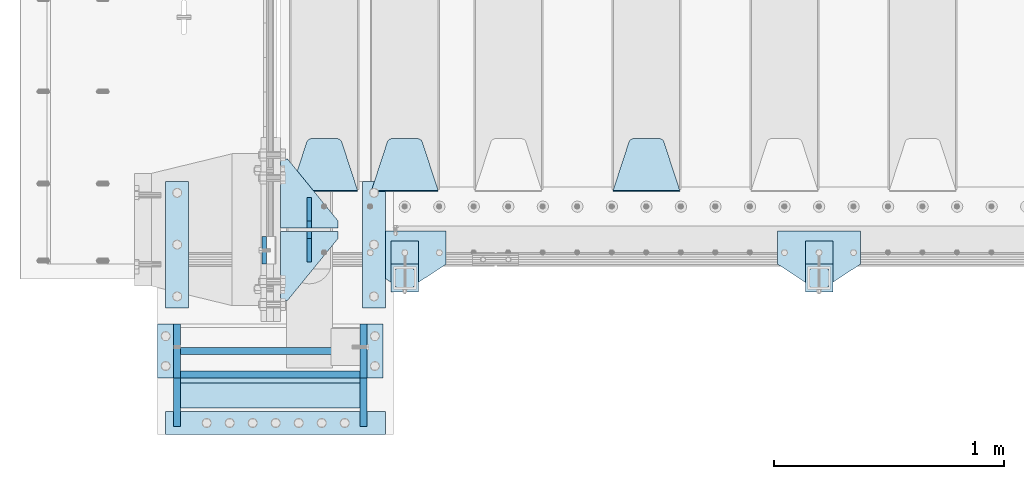
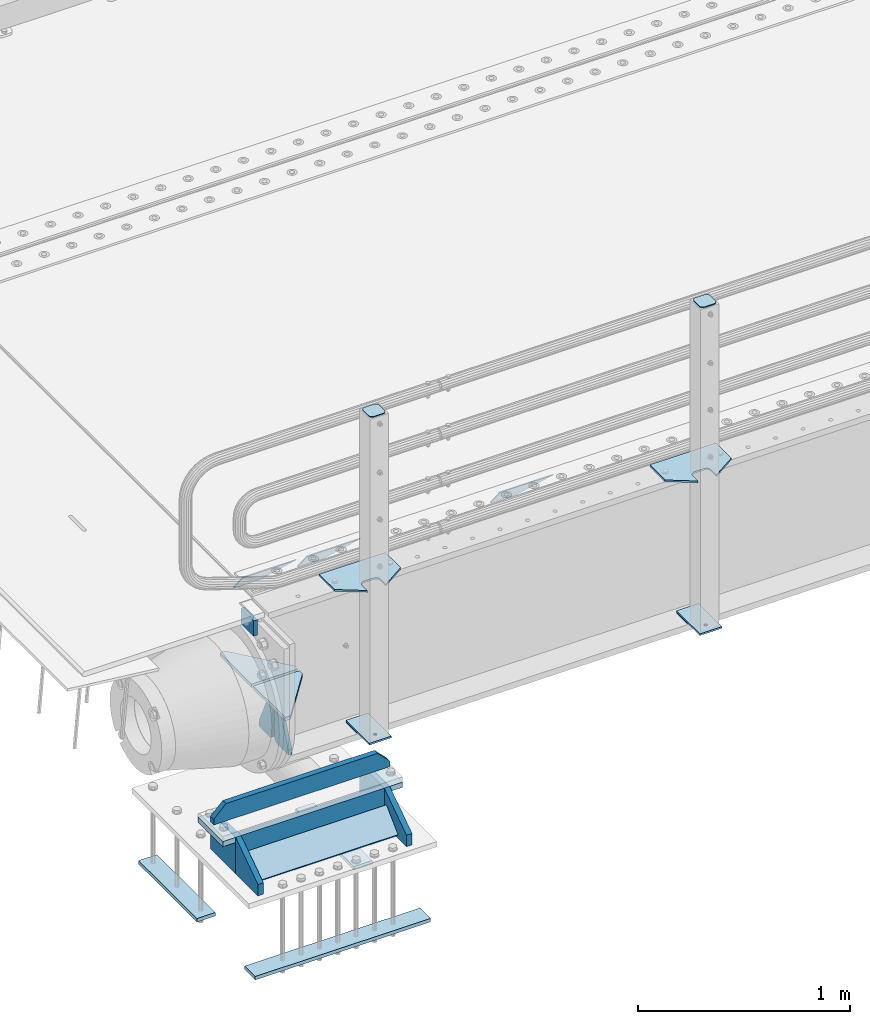
# One storey, part 195 of 242: 28 plates.
"""IFC2X3 building model written with IfcOpenShell, lengths in millimetres."""

from ifc_helpers import new_model, si_unit, frame, origin_with_axes, place, context, subcontext, project, spatial, faceted_brep, material, type_object, element, save


model = new_model("IFC2X3")

# Units and contexts
model_context = context("Model", 3, precision=1e-05, world=origin_with_axes())
body_context = subcontext(model_context, "Body", "Model", "MODEL_VIEW")
ifc_project = project(units=[si_unit("LENGTHUNIT", "METRE", prefix="MILLI"), si_unit("AREAUNIT", "SQUARE_METRE"), si_unit("VOLUMEUNIT", "CUBIC_METRE"), si_unit("MASSUNIT", "GRAM", prefix="KILO"), si_unit("TIMEUNIT", "SECOND"), si_unit("PLANEANGLEUNIT", "RADIAN"), si_unit("SOLIDANGLEUNIT", "STERADIAN"), si_unit("THERMODYNAMICTEMPERATUREUNIT", "DEGREE_CELSIUS"), si_unit("LUMINOUSINTENSITYUNIT", "LUMEN")], contexts=[model_context])

# Site, building, storey
site_placement = place(None, origin_with_axes())
site = spatial("IfcSite", under=ifc_project, at=site_placement, CompositionType="ELEMENT")
building_placement = place(site_placement, origin_with_axes())
building = spatial("IfcBuilding", under=site, at=building_placement, Name="Standard", CompositionType="ELEMENT")
storey_placement = place(building_placement, origin_with_axes())
storey = spatial("IfcBuildingStorey", under=building, at=storey_placement, Name="Undefined", CompositionType="ELEMENT", Elevation=0.0)

# Plates
ifc_material_1 = material(Name="STEEL/S355N")
plate_type_1 = type_object("IfcPlateType", PredefinedType="NOTDEFINED")
plate_1_placement = place(storey_placement, frame((-42510.0, -24029.9995540189, -106.00008741594), z_axis=(1.0000003385235e-09, -0.999999999987744, -4.95099999993936e-06), x_axis=(0.0, -4.95099997756316e-06, 0.999999999987744)))
element("IfcPlate", 1, at=plate_1_placement, inside=storey, type_object=plate_type_1, material=ifc_material_1, context=body_context, shape_type="Brep", body=[
    faceted_brep([(0.0, -10.0, 0.0), (5.70725632087488e-07, -10.0, 120.0), (5.70725632087488e-07, 10.0, 120.0), (0.0, 10.0, 0.0), (89.9999999999979, -10.0, 120.000000000004), (89.9999999999979, 10.0, 120.000000000004), (90.0, -10.0, 1.09139364212751e-11), (90.0, 10.0, 1.09139364212751e-11)], [[[0, 1, 2, 3]], [[1, 4, 5, 2]], [[4, 6, 7, 5]], [[6, 0, 3, 7]], [[5, 7, 3, 2]], [[6, 4, 1, 0]]]),
])
ifc_material_2 = material(Name="STEEL/S355J2")
plate_type_2 = type_object("IfcPlateType", PredefinedType="NOTDEFINED")
plate_2_placement = place(storey_placement, frame((-39920.0, -24005.0, 5.00000000004911), z_axis=(0.0, -1.0, 0.0), x_axis=(-1.0, 0.0, 0.0)))
element("IfcPlate", 2, at=plate_2_placement, inside=storey, type_object=plate_type_2, material=ifc_material_2, context=body_context, shape_type="Brep", body=[
    faceted_brep([(0.0, -5.0, 0.0), (2.31396552408114e-06, -5.0, 145.0), (2.31396552408114e-06, 5.0, 145.0), (0.0, 5.0, 0.0), (130.0, -5.0, 230.0), (130.0, 5.0, 230.0), (130.0, -5.0, 180.0), (130.0, 5.0, 180.0), (130.48036798992, -5.0, 175.122741949595), (130.48036798992, 5.0, 175.122741949595), (131.903011687216, -5.0, 170.432914190871), (131.903011687216, 5.0, 170.432914190871), (134.213259692435, -5.0, 166.110744174512), (134.213259692435, 5.0, 166.110744174512), (137.322330470335, -5.0, 162.322330470335), (137.322330470335, 5.0, 162.322330470335), (141.110744174512, -5.0, 159.213259692435), (141.110744174512, 5.0, 159.213259692435), (145.432914190871, -5.0, 156.903011687216), (145.432914190871, 5.0, 156.903011687216), (150.122741949595, -5.0, 155.48036798992), (150.122741949595, 5.0, 155.48036798992), (155.0, -5.0, 155.0), (155.0, 5.0, 155.0), (205.0, -5.0, 155.0), (205.0, 5.0, 155.0), (209.877258050405, -5.0, 155.48036798992), (209.877258050405, 5.0, 155.48036798992), (214.567085809129, -5.0, 156.903011687216), (214.567085809129, 5.0, 156.903011687216), (218.889255825488, -5.0, 159.213259692435), (218.889255825488, 5.0, 159.213259692435), (222.677669529665, -5.0, 162.322330470335), (222.677669529665, 5.0, 162.322330470335), (225.786740307565, -5.0, 166.110744174512), (225.786740307565, 5.0, 166.110744174512), (228.096988312784, -5.0, 170.432914190871), (228.096988312784, 5.0, 170.432914190871), (229.51963201008, -5.0, 175.122741949595), (229.51963201008, 5.0, 175.122741949595), (230.0, -5.0, 180.0), (230.0, 5.0, 180.0), (230.0, -5.0, 230.0), (230.0, 5.0, 230.0), (360.0, -5.0, 145.0), (360.0, 5.0, 145.0), (360.0, -5.0, -7.27595761418343e-12), (360.0, 5.0, -7.27595761418343e-12)], [[[0, 1, 2, 3]], [[1, 4, 5, 2]], [[4, 6, 7, 5]], [[6, 8, 9, 7]], [[8, 10, 11, 9]], [[10, 12, 13, 11]], [[12, 14, 15, 13]], [[14, 16, 17, 15]], [[16, 18, 19, 17]], [[18, 20, 21, 19]], [[20, 22, 23, 21]], [[22, 24, 25, 23]], [[24, 26, 27, 25]], [[26, 28, 29, 27]], [[28, 30, 31, 29]], [[30, 32, 33, 31]], [[32, 34, 35, 33]], [[34, 36, 37, 35]], [[36, 38, 39, 37]], [[38, 40, 41, 39]], [[40, 42, 43, 41]], [[42, 44, 45, 43]], [[44, 46, 47, 45]], [[46, 0, 3, 47]], [[5, 7, 9, 11, 13, 15, 17, 19, 21, 23, 25, 27, 29, 31, 33, 35, 37, 39, 41, 43, 45, 47, 3, 2]], [[46, 44, 42, 40, 38, 36, 34, 32, 30, 28, 26, 24, 22, 20, 18, 16, 14, 12, 10, 8, 6, 4, 1, 0]]]),
])
plate_3_placement = place(storey_placement, frame((-41720.0, -24005.0, 5.00000000004911), z_axis=(0.0, -1.0, 0.0), x_axis=(-1.0, 0.0, 0.0)))
element("IfcPlate", 3, at=plate_3_placement, inside=storey, type_object=plate_type_2, material=ifc_material_2, context=body_context, shape_type="Brep", body=[
    faceted_brep([(0.0, -5.0, 0.0), (2.31396552408114e-06, -5.0, 145.0), (2.31396552408114e-06, 5.0, 145.0), (0.0, 5.0, 0.0), (130.0, -5.0, 230.0), (130.0, 5.0, 230.0), (130.0, -5.0, 180.0), (130.0, 5.0, 180.0), (130.48036798992, -5.0, 175.122741949595), (130.48036798992, 5.0, 175.122741949595), (131.903011687216, -5.0, 170.432914190871), (131.903011687216, 5.0, 170.432914190871), (134.213259692435, -5.0, 166.110744174512), (134.213259692435, 5.0, 166.110744174512), (137.322330470335, -5.0, 162.322330470335), (137.322330470335, 5.0, 162.322330470335), (141.110744174512, -5.0, 159.213259692435), (141.110744174512, 5.0, 159.213259692435), (145.432914190871, -5.0, 156.903011687216), (145.432914190871, 5.0, 156.903011687216), (150.122741949595, -5.0, 155.48036798992), (150.122741949595, 5.0, 155.48036798992), (155.0, -5.0, 155.0), (155.0, 5.0, 155.0), (205.0, -5.0, 155.0), (205.0, 5.0, 155.0), (209.877258050405, -5.0, 155.48036798992), (209.877258050405, 5.0, 155.48036798992), (214.567085809129, -5.0, 156.903011687216), (214.567085809129, 5.0, 156.903011687216), (218.889255825488, -5.0, 159.213259692435), (218.889255825488, 5.0, 159.213259692435), (222.677669529665, -5.0, 162.322330470335), (222.677669529665, 5.0, 162.322330470335), (225.786740307565, -5.0, 166.110744174512), (225.786740307565, 5.0, 166.110744174512), (228.096988312784, -5.0, 170.432914190871), (228.096988312784, 5.0, 170.432914190871), (229.51963201008, -5.0, 175.122741949595), (229.51963201008, 5.0, 175.122741949595), (230.0, -5.0, 180.0), (230.0, 5.0, 180.0), (230.0, -5.0, 230.0), (230.0, 5.0, 230.0), (360.0, -5.0, 145.0), (360.0, 5.0, 145.0), (360.0, -5.0, -7.27595761418343e-12), (360.0, 5.0, -7.27595761418343e-12)], [[[0, 1, 2, 3]], [[1, 4, 5, 2]], [[4, 6, 7, 5]], [[6, 8, 9, 7]], [[8, 10, 11, 9]], [[10, 12, 13, 11]], [[12, 14, 15, 13]], [[14, 16, 17, 15]], [[16, 18, 19, 17]], [[18, 20, 21, 19]], [[20, 22, 23, 21]], [[22, 24, 25, 23]], [[24, 26, 27, 25]], [[26, 28, 29, 27]], [[28, 30, 31, 29]], [[30, 32, 33, 31]], [[32, 34, 35, 33]], [[34, 36, 37, 35]], [[36, 38, 39, 37]], [[38, 40, 41, 39]], [[40, 42, 43, 41]], [[42, 44, 45, 43]], [[44, 46, 47, 45]], [[46, 0, 3, 47]], [[5, 7, 9, 11, 13, 15, 17, 19, 21, 23, 25, 27, 29, 31, 33, 35, 37, 39, 41, 43, 45, 47, 3, 2]], [[46, 44, 42, 40, 38, 36, 34, 32, 30, 28, 26, 24, 22, 20, 18, 16, 14, 12, 10, 8, 6, 4, 1, 0]]]),
])
plate_type_3 = type_object("IfcPlateType", PredefinedType="NOTDEFINED")
for number, where, z_axis, x_axis in (
    (4, (-40040.0000000001, -24050.0000000002, -850.000000000002), (0.0, -1.0, 0.0), (-1.0, 0.0, 0.0)),
    (5, (-41840.0000000001, -24050.0000000002, -850.000000000002), (0.0, -1.0, 0.0), (-1.0, 0.0, 0.0)),
):
    element("IfcPlate", number, at=place(storey_placement, frame(where, z_axis=z_axis, x_axis=x_axis)), inside=storey, type_object=plate_type_3, material=ifc_material_2, context=body_context, shape_type="Brep", body=[
        faceted_brep([(53.6360389691836, -5.0, 176.363961030471), (53.6360389691836, 5.0, 176.363961030471), (59.9999999998618, 5.0, 178.999999999793), (59.9999999998618, -5.0, 178.999999999793), (66.3639610305399, 5.0, 176.363961030471), (66.3639610305399, -5.0, 176.363961030471), (68.9999999998618, 5.0, 169.999999999793), (68.9999999998618, -5.0, 169.999999999793), (66.3639610305399, 5.0, 163.636038969114), (66.3639610305399, -5.0, 163.636038969114), (59.9999999998618, 5.0, 160.999999999793), (59.9999999998618, -5.0, 160.999999999793), (53.6360389691836, 5.0, 163.636038969114), (53.6360389691836, -5.0, 163.636038969114), (50.9999999998618, 5.0, 169.999999999793), (50.9999999998618, -5.0, 169.999999999793), (120.0, -5.0, 0.0), (120.0, -5.0, 220.0), (0.0, -5.0, 220.0), (0.0, -5.0, 0.0), (0.0, 5.0, 0.0), (120.0, 5.0, 0.0), (120.0, 5.0, 220.0), (0.0, 5.0, 220.0)], [[[0, 1, 2, 3]], [[3, 2, 4, 5]], [[5, 4, 6, 7]], [[7, 6, 8, 9]], [[9, 8, 10, 11]], [[11, 10, 12, 13]], [[13, 12, 14, 15]], [[15, 14, 1, 0]], [[16, 17, 18, 19], [3, 5, 7, 9, 11, 13, 15, 0]], [[16, 19, 20, 21]], [[17, 16, 21, 22]], [[18, 17, 22, 23]], [[19, 18, 23, 20]], [[22, 21, 20, 23], [10, 8, 6, 4, 2, 1, 14, 12]]]),
    ])
plate_type_4 = type_object("IfcPlateType", PredefinedType="NOTDEFINED")
plate_4_placement = place(storey_placement, frame((-40144.0000000001, -24166.0000000002, 1012.50000000001), z_axis=(0.0, -1.0, 0.0), x_axis=(1.0, 0.0, 0.0)))
element("IfcPlate", 6, at=plate_4_placement, inside=storey, type_object=plate_type_4, material=ifc_material_2, context=body_context, shape_type="Brep", body=[
    faceted_brep([(0.0, -2.5, 19.0), (0.0, -2.5, 69.0), (0.0, 2.5, 69.0), (0.0, 2.5, 19.0), (0.476369668544066, -2.5, 73.2278977451715), (0.476369668544066, 2.5, 73.2278977451715), (1.88159150985302, -2.5, 77.2437910432345), (1.88159150985302, 2.5, 77.2437910432345), (4.14520183310742, -2.5, 80.8463062353148), (4.14520183310742, 2.5, 80.8463062353148), (7.15369376468516, -2.5, 83.8547981668926), (7.15369376468516, 2.5, 83.8547981668926), (10.7562089567655, -2.5, 86.118408490147), (10.7562089567655, 2.5, 86.118408490147), (14.7721022548285, -2.5, 87.5236303314559), (14.7721022548285, 2.5, 87.5236303314559), (19.0, -2.5, 88.0), (19.0, 2.5, 88.0), (69.0, -2.5, 88.0), (69.0, 2.5, 88.0), (73.2278977451715, -2.5, 87.5236303314559), (73.2278977451715, 2.5, 87.5236303314559), (77.2437910432345, -2.5, 86.118408490147), (77.2437910432345, 2.5, 86.118408490147), (80.8463062353148, -2.5, 83.8547981668926), (80.8463062353148, 2.5, 83.8547981668926), (83.8547981668926, -2.5, 80.8463062353148), (83.8547981668926, 2.5, 80.8463062353148), (86.118408490147, -2.5, 77.2437910432345), (86.118408490147, 2.5, 77.2437910432345), (87.5236303314559, -2.5, 73.2278977451715), (87.5236303314559, 2.5, 73.2278977451715), (88.0, -2.5, 69.0), (88.0, 2.5, 69.0), (88.0, -2.5, 19.0), (88.0, 2.5, 19.0), (87.5236303314559, -2.5, 14.7721022548285), (87.5236303314559, 2.5, 14.7721022548285), (86.118408490147, -2.5, 10.7562089567655), (86.118408490147, 2.5, 10.7562089567655), (83.8547981668926, -2.5, 7.15369376468516), (83.8547981668926, 2.5, 7.15369376468516), (80.8463062353148, -2.5, 4.14520183310742), (80.8463062353148, 2.5, 4.14520183310742), (77.2437910432345, -2.5, 1.88159150985302), (77.2437910432345, 2.5, 1.88159150985302), (73.2278977451715, -2.5, 0.476369668544066), (73.2278977451715, 2.5, 0.476369668544066), (69.0, -2.5, 0.0), (69.0, 2.5, 0.0), (19.0, -2.5, 0.0), (19.0, 2.5, 0.0), (14.7721022548285, -2.5, 0.476369668544066), (14.7721022548285, 2.5, 0.476369668544066), (10.7562089567655, -2.5, 1.88159150985302), (10.7562089567655, 2.5, 1.88159150985302), (7.15369376468516, -2.5, 4.14520183310742), (7.15369376468516, 2.5, 4.14520183310742), (4.14520183310742, -2.5, 7.15369376468516), (4.14520183310742, 2.5, 7.15369376468516), (1.88159150985302, -2.5, 10.7562089567655), (1.88159150985302, 2.5, 10.7562089567655), (0.476369668544066, -2.5, 14.7721022548285), (0.476369668544066, 2.5, 14.7721022548285)], [[[0, 1, 2, 3]], [[1, 4, 5, 2]], [[4, 6, 7, 5]], [[6, 8, 9, 7]], [[8, 10, 11, 9]], [[10, 12, 13, 11]], [[12, 14, 15, 13]], [[14, 16, 17, 15]], [[16, 18, 19, 17]], [[18, 20, 21, 19]], [[20, 22, 23, 21]], [[22, 24, 25, 23]], [[24, 26, 27, 25]], [[26, 28, 29, 27]], [[28, 30, 31, 29]], [[30, 32, 33, 31]], [[32, 34, 35, 33]], [[34, 36, 37, 35]], [[36, 38, 39, 37]], [[38, 40, 41, 39]], [[40, 42, 43, 41]], [[42, 44, 45, 43]], [[44, 46, 47, 45]], [[46, 48, 49, 47]], [[48, 50, 51, 49]], [[50, 52, 53, 51]], [[52, 54, 55, 53]], [[54, 56, 57, 55]], [[56, 58, 59, 57]], [[58, 60, 61, 59]], [[60, 62, 63, 61]], [[62, 0, 3, 63]], [[5, 7, 9, 11, 13, 15, 17, 19, 21, 23, 25, 27, 29, 31, 33, 35, 37, 39, 41, 43, 45, 47, 49, 51, 53, 55, 57, 59, 61, 63, 3, 2]], [[62, 60, 58, 56, 54, 52, 50, 48, 46, 44, 42, 40, 38, 36, 34, 32, 30, 28, 26, 24, 22, 20, 18, 16, 14, 12, 10, 8, 6, 4, 1, 0]]]),
])
plate_5_placement = place(storey_placement, frame((-41944.0000000001, -24166.0000000002, 1012.50000000001), z_axis=(0.0, -1.0, 0.0), x_axis=(1.0, 0.0, 0.0)))
element("IfcPlate", 7, at=plate_5_placement, inside=storey, type_object=plate_type_4, material=ifc_material_2, context=body_context, shape_type="Brep", body=[
    faceted_brep([(0.0, -2.5, 19.0), (0.0, -2.5, 69.0), (0.0, 2.5, 69.0), (0.0, 2.5, 19.0), (0.476369668544066, -2.5, 73.2278977451715), (0.476369668544066, 2.5, 73.2278977451715), (1.88159150985302, -2.5, 77.2437910432345), (1.88159150985302, 2.5, 77.2437910432345), (4.14520183310742, -2.5, 80.8463062353148), (4.14520183310742, 2.5, 80.8463062353148), (7.15369376468516, -2.5, 83.8547981668926), (7.15369376468516, 2.5, 83.8547981668926), (10.7562089567655, -2.5, 86.118408490147), (10.7562089567655, 2.5, 86.118408490147), (14.7721022548285, -2.5, 87.5236303314559), (14.7721022548285, 2.5, 87.5236303314559), (19.0, -2.5, 88.0), (19.0, 2.5, 88.0), (69.0, -2.5, 88.0), (69.0, 2.5, 88.0), (73.2278977451715, -2.5, 87.5236303314559), (73.2278977451715, 2.5, 87.5236303314559), (77.2437910432345, -2.5, 86.118408490147), (77.2437910432345, 2.5, 86.118408490147), (80.8463062353148, -2.5, 83.8547981668926), (80.8463062353148, 2.5, 83.8547981668926), (83.8547981668926, -2.5, 80.8463062353148), (83.8547981668926, 2.5, 80.8463062353148), (86.118408490147, -2.5, 77.2437910432345), (86.118408490147, 2.5, 77.2437910432345), (87.5236303314559, -2.5, 73.2278977451715), (87.5236303314559, 2.5, 73.2278977451715), (88.0, -2.5, 69.0), (88.0, 2.5, 69.0), (88.0, -2.5, 19.0), (88.0, 2.5, 19.0), (87.5236303314559, -2.5, 14.7721022548285), (87.5236303314559, 2.5, 14.7721022548285), (86.118408490147, -2.5, 10.7562089567655), (86.118408490147, 2.5, 10.7562089567655), (83.8547981668926, -2.5, 7.15369376468516), (83.8547981668926, 2.5, 7.15369376468516), (80.8463062353148, -2.5, 4.14520183310742), (80.8463062353148, 2.5, 4.14520183310742), (77.2437910432345, -2.5, 1.88159150985302), (77.2437910432345, 2.5, 1.88159150985302), (73.2278977451715, -2.5, 0.476369668544066), (73.2278977451715, 2.5, 0.476369668544066), (69.0, -2.5, 0.0), (69.0, 2.5, 0.0), (19.0, -2.5, 0.0), (19.0, 2.5, 0.0), (14.7721022548285, -2.5, 0.476369668544066), (14.7721022548285, 2.5, 0.476369668544066), (10.7562089567655, -2.5, 1.88159150985302), (10.7562089567655, 2.5, 1.88159150985302), (7.15369376468516, -2.5, 4.14520183310742), (7.15369376468516, 2.5, 4.14520183310742), (4.14520183310742, -2.5, 7.15369376468516), (4.14520183310742, 2.5, 7.15369376468516), (1.88159150985302, -2.5, 10.7562089567655), (1.88159150985302, 2.5, 10.7562089567655), (0.476369668544066, -2.5, 14.7721022548285), (0.476369668544066, 2.5, 14.7721022548285)], [[[0, 1, 2, 3]], [[1, 4, 5, 2]], [[4, 6, 7, 5]], [[6, 8, 9, 7]], [[8, 10, 11, 9]], [[10, 12, 13, 11]], [[12, 14, 15, 13]], [[14, 16, 17, 15]], [[16, 18, 19, 17]], [[18, 20, 21, 19]], [[20, 22, 23, 21]], [[22, 24, 25, 23]], [[24, 26, 27, 25]], [[26, 28, 29, 27]], [[28, 30, 31, 29]], [[30, 32, 33, 31]], [[32, 34, 35, 33]], [[34, 36, 37, 35]], [[36, 38, 39, 37]], [[38, 40, 41, 39]], [[40, 42, 43, 41]], [[42, 44, 45, 43]], [[44, 46, 47, 45]], [[46, 48, 49, 47]], [[48, 50, 51, 49]], [[50, 52, 53, 51]], [[52, 54, 55, 53]], [[54, 56, 57, 55]], [[56, 58, 59, 57]], [[58, 60, 61, 59]], [[60, 62, 63, 61]], [[62, 0, 3, 63]], [[5, 7, 9, 11, 13, 15, 17, 19, 21, 23, 25, 27, 29, 31, 33, 35, 37, 39, 41, 43, 45, 47, 49, 51, 53, 55, 57, 59, 61, 63, 3, 2]], [[62, 60, 58, 56, 54, 52, 50, 48, 46, 44, 42, 40, 38, 36, 34, 32, 30, 28, 26, 24, 22, 20, 18, 16, 14, 12, 10, 8, 6, 4, 1, 0]]]),
])
plate_type_5 = type_object("IfcPlateType", PredefinedType="NOTDEFINED")
for number, where, z_axis, x_axis in (
    (8, (-40040.0000000001, -24050.0000000002, -857.500000000002), (0.0, -1.0, 0.0), (-1.0, 0.0, 0.0)),
    (9, (-41840.0000000001, -24050.0000000002, -857.500000000002), (0.0, -1.0, 0.0), (-1.0, 0.0, 0.0)),
):
    element("IfcPlate", number, at=place(storey_placement, frame(where, z_axis=z_axis, x_axis=x_axis)), inside=storey, type_object=plate_type_5, material=ifc_material_2, context=body_context, shape_type="Brep", body=[
        faceted_brep([(0.0, -2.5, 0.0), (0.0, -2.5, 100.0), (0.0, 2.5, 100.0), (0.0, 2.5, 0.0), (120.0, -2.5, 100.0), (120.0, 2.5, 100.0), (120.0, -2.5, 0.0), (120.0, 2.5, 0.0)], [[[0, 1, 2, 3]], [[1, 4, 5, 2]], [[4, 6, 7, 5]], [[6, 0, 3, 7]], [[5, 7, 3, 2]], [[6, 4, 1, 0]]]),
    ])
plate_type_6 = type_object("IfcPlateType", PredefinedType="NOTDEFINED")
plate_6_placement = place(storey_placement, frame((-40705.0, -23831.767766953, -1.76776695296758), z_axis=(0.0, 0.707106781186547, -0.707106781186548), x_axis=(-1.0, 0.0, 0.0)))
element("IfcPlate", 10, at=plate_6_placement, inside=storey, type_object=plate_type_6, material=ifc_material_1, context=body_context, shape_type="Brep", body=[
    faceted_brep([(0.0, -2.5, 0.0), (69.345504679477, -2.50000000000182, 300.171731424829), (69.345504679477, 2.5, 300.171731424829), (0.0, 2.5, 0.0), (70.9274061199576, -2.5, 304.897442415398), (70.9274061199576, 2.5, 304.897442415398), (73.3818627772307, -2.5, 309.234538108525), (73.3818627772307, 2.50000000000182, 309.234538108529), (76.6187032999551, -2.5, 313.023683126101), (76.6187032999551, 2.50000000000182, 313.023683126103), (80.5190132704993, -2.5, 316.12567259537), (80.5190132704993, 2.5, 316.12567259537), (84.9395038596849, -2.5, 318.426546230474), (84.9395038596849, 2.50000000000182, 318.426546230476), (89.7177759439219, -2.49999999999818, 319.841774983273), (89.7177759439219, 2.50000000000182, 319.841774983273), (94.678286292652, -2.5, 320.319366455076), (94.678286292652, 2.5, 320.319366455076), (195.321713707348, -2.5, 320.319366455076), (195.321713707348, 2.5, 320.319366455076), (200.282224056078, -2.5, 319.841774983272), (200.282224056078, 2.50000000000182, 319.841774983273), (205.060496140315, -2.5, 318.426546230474), (205.060496140315, 2.49999999999818, 318.426546230474), (209.480986729501, -2.49999999999818, 316.12567259537), (209.480986729501, 2.5, 316.12567259537), (213.381296700045, -2.5, 313.023683126101), (213.381296700045, 2.49999999999818, 313.023683126101), (216.618137222769, -2.5, 309.234538108525), (216.618137222769, 2.5, 309.234538108523), (219.072593880042, -2.49999999999818, 304.897442415398), (219.072593880042, 2.50000000000182, 304.897442415398), (220.654495320523, -2.50000000000182, 300.171731424829), (220.654495320523, 2.5, 300.171731424829), (290.0, -2.5, 0.0), (290.0, 2.5, -1.81898940354586e-12)], [[[0, 1, 2, 3]], [[1, 4, 5, 2]], [[4, 6, 7, 5]], [[6, 8, 9, 7]], [[8, 10, 11, 9]], [[10, 12, 13, 11]], [[12, 14, 15, 13]], [[14, 16, 17, 15]], [[16, 18, 19, 17]], [[18, 20, 21, 19]], [[20, 22, 23, 21]], [[22, 24, 25, 23]], [[24, 26, 27, 25]], [[26, 28, 29, 27]], [[28, 30, 31, 29]], [[30, 32, 33, 31]], [[32, 34, 35, 33]], [[34, 0, 3, 35]], [[5, 7, 9, 11, 13, 15, 17, 19, 21, 23, 25, 27, 29, 31, 33, 35, 3, 2]], [[34, 32, 30, 28, 26, 24, 22, 20, 18, 16, 14, 12, 10, 8, 6, 4, 1, 0]]]),
])
plate_7_placement = place(storey_placement, frame((-41755.0, -23831.767766953, -1.76776695296758), z_axis=(0.0, 0.707106781186547, -0.707106781186548), x_axis=(-1.0, 0.0, 0.0)))
element("IfcPlate", 11, at=plate_7_placement, inside=storey, type_object=plate_type_6, material=ifc_material_1, context=body_context, shape_type="Brep", body=[
    faceted_brep([(0.0, -2.5, 0.0), (69.345504679477, -2.50000000000182, 300.171731424829), (69.345504679477, 2.5, 300.171731424829), (0.0, 2.5, 0.0), (70.9274061199576, -2.5, 304.897442415398), (70.9274061199576, 2.5, 304.897442415398), (73.3818627772307, -2.5, 309.234538108525), (73.3818627772307, 2.50000000000182, 309.234538108529), (76.6187032999551, -2.5, 313.023683126101), (76.6187032999551, 2.50000000000182, 313.023683126103), (80.5190132704993, -2.5, 316.12567259537), (80.5190132704993, 2.5, 316.12567259537), (84.9395038596849, -2.5, 318.426546230474), (84.9395038596849, 2.50000000000182, 318.426546230476), (89.7177759439219, -2.49999999999818, 319.841774983273), (89.7177759439219, 2.50000000000182, 319.841774983273), (94.678286292652, -2.5, 320.319366455076), (94.678286292652, 2.5, 320.319366455076), (195.321713707348, -2.5, 320.319366455076), (195.321713707348, 2.5, 320.319366455076), (200.282224056078, -2.5, 319.841774983272), (200.282224056078, 2.50000000000182, 319.841774983273), (205.060496140315, -2.5, 318.426546230474), (205.060496140315, 2.49999999999818, 318.426546230474), (209.480986729501, -2.49999999999818, 316.12567259537), (209.480986729501, 2.5, 316.12567259537), (213.381296700045, -2.5, 313.023683126101), (213.381296700045, 2.49999999999818, 313.023683126101), (216.618137222769, -2.5, 309.234538108525), (216.618137222769, 2.5, 309.234538108523), (219.072593880042, -2.49999999999818, 304.897442415398), (219.072593880042, 2.50000000000182, 304.897442415398), (220.654495320523, -2.50000000000182, 300.171731424829), (220.654495320523, 2.5, 300.171731424829), (290.0, -2.5, 0.0), (290.0, 2.5, -1.81898940354586e-12)], [[[0, 1, 2, 3]], [[1, 4, 5, 2]], [[4, 6, 7, 5]], [[6, 8, 9, 7]], [[8, 10, 11, 9]], [[10, 12, 13, 11]], [[12, 14, 15, 13]], [[14, 16, 17, 15]], [[16, 18, 19, 17]], [[18, 20, 21, 19]], [[20, 22, 23, 21]], [[22, 24, 25, 23]], [[24, 26, 27, 25]], [[26, 28, 29, 27]], [[28, 30, 31, 29]], [[30, 32, 33, 31]], [[32, 34, 35, 33]], [[34, 0, 3, 35]], [[5, 7, 9, 11, 13, 15, 17, 19, 21, 23, 25, 27, 29, 31, 33, 35, 3, 2]], [[34, 32, 30, 28, 26, 24, 22, 20, 18, 16, 14, 12, 10, 8, 6, 4, 1, 0]]]),
])
plate_8_placement = place(storey_placement, frame((-42105.0, -23831.767766953, -1.76776695296758), z_axis=(0.0, 0.707106781186547, -0.707106781186548), x_axis=(-1.0, 0.0, 0.0)))
element("IfcPlate", 12, at=plate_8_placement, inside=storey, type_object=plate_type_6, material=ifc_material_1, context=body_context, shape_type="Brep", body=[
    faceted_brep([(0.0, -2.5, 0.0), (69.345504679477, -2.50000000000182, 300.171731424829), (69.345504679477, 2.5, 300.171731424829), (0.0, 2.5, 0.0), (70.9274061199576, -2.5, 304.897442415398), (70.9274061199576, 2.5, 304.897442415398), (73.3818627772307, -2.5, 309.234538108525), (73.3818627772307, 2.50000000000182, 309.234538108529), (76.6187032999551, -2.5, 313.023683126101), (76.6187032999551, 2.50000000000182, 313.023683126103), (80.5190132704993, -2.5, 316.12567259537), (80.5190132704993, 2.5, 316.12567259537), (84.9395038596849, -2.5, 318.426546230474), (84.9395038596849, 2.50000000000182, 318.426546230476), (89.7177759439219, -2.49999999999818, 319.841774983273), (89.7177759439219, 2.50000000000182, 319.841774983273), (94.678286292652, -2.5, 320.319366455076), (94.678286292652, 2.5, 320.319366455076), (195.321713707348, -2.5, 320.319366455076), (195.321713707348, 2.5, 320.319366455076), (200.282224056078, -2.5, 319.841774983272), (200.282224056078, 2.50000000000182, 319.841774983273), (205.060496140315, -2.5, 318.426546230474), (205.060496140315, 2.49999999999818, 318.426546230474), (209.480986729501, -2.49999999999818, 316.12567259537), (209.480986729501, 2.5, 316.12567259537), (213.381296700045, -2.5, 313.023683126101), (213.381296700045, 2.49999999999818, 313.023683126101), (216.618137222769, -2.5, 309.234538108525), (216.618137222769, 2.5, 309.234538108523), (219.072593880042, -2.49999999999818, 304.897442415398), (219.072593880042, 2.50000000000182, 304.897442415398), (220.654495320523, -2.50000000000182, 300.171731424829), (220.654495320523, 2.5, 300.171731424829), (290.0, -2.5, 0.0), (290.0, 2.5, -1.81898940354586e-12)], [[[0, 1, 2, 3]], [[1, 4, 5, 2]], [[4, 6, 7, 5]], [[6, 8, 9, 7]], [[8, 10, 11, 9]], [[10, 12, 13, 11]], [[12, 14, 15, 13]], [[14, 16, 17, 15]], [[16, 18, 19, 17]], [[18, 20, 21, 19]], [[20, 22, 23, 21]], [[22, 24, 25, 23]], [[24, 26, 27, 25]], [[26, 28, 29, 27]], [[28, 30, 31, 29]], [[30, 32, 33, 31]], [[32, 34, 35, 33]], [[34, 0, 3, 35]], [[5, 7, 9, 11, 13, 15, 17, 19, 21, 23, 25, 27, 29, 31, 33, 35, 3, 2]], [[34, 32, 30, 28, 26, 24, 22, 20, 18, 16, 14, 12, 10, 8, 6, 4, 1, 0]]]),
])
plate_type_7 = type_object("IfcPlateType", PredefinedType="NOTDEFINED")
for number, where, z_axis, x_axis in (
    (13, (-42190.0, -23992.0, -515.0), (0.0, 1.0, 0.0), (-1.0, 0.0, 0.0)),
    (14, (-42190.0, -24008.0, -515.0), (0.0, -1.0, 0.0), (-1.0, 0.0, 0.0)),
):
    element("IfcPlate", number, at=place(storey_placement, frame(where, z_axis=z_axis, x_axis=x_axis)), inside=storey, type_object=plate_type_7, material=ifc_material_1, context=body_context, shape_type="Brep", body=[
        faceted_brep([(0.0, -10.0, 0.0), (0.0, -10.0, 30.0), (0.0, 10.0, 30.0), (0.0, 10.0, 0.0), (220.0, -10.0, 300.0), (220.0, 10.0, 300.0), (250.0, -10.0, 300.0), (250.0, 10.0, 300.0), (250.0, -10.0, 0.0), (250.0, 10.0, 0.0)], [[[0, 1, 2, 3]], [[1, 4, 5, 2]], [[4, 6, 7, 5]], [[6, 8, 9, 7]], [[8, 0, 3, 9]], [[5, 7, 9, 3, 2]], [[8, 6, 4, 1, 0]]]),
    ])
plate_type_8 = type_object("IfcPlateType", PredefinedType="NOTDEFINED")
for number, where, z_axis, x_axis in (
    (15, (-42315.0, -23860.0, -865.0), (0.0, 0.0, 1.0), (0.0, -1.0, 0.0)),
    (16, (-42315.0, -24140.0, -865.0), (0.0, 0.0, 1.0), (0.0, 1.0, 0.0)),
):
    element("IfcPlate", number, at=place(storey_placement, frame(where, z_axis=z_axis, x_axis=x_axis)), inside=storey, type_object=plate_type_8, material=ifc_material_1, context=body_context, shape_type="Brep", body=[
        faceted_brep([(0.0, -10.0, 0.0), (0.0, -10.0, 30.0), (0.0, 10.0, 30.0), (0.0, 10.0, 0.0), (102.0, -10.0, 250.0), (102.0, 10.0, 250.0), (132.0, -10.0, 250.0), (132.0, 10.0, 250.0), (132.0, -10.0, 30.0), (132.0, 10.0, 30.0), (131.544232590368, -10.0, 24.790554669992), (131.544232590368, 10.0, 24.790554669992), (130.190778623579, -10.0, 19.7393957002299), (130.190778623579, 10.0, 19.7393957002299), (127.980762113533, -10.0, 15.0), (127.980762113533, 10.0, 15.0), (124.98133329357, -10.0, 10.7163717094038), (124.98133329357, 10.0, 10.7163717094038), (121.283628290596, -10.0, 7.01866670643062), (121.283628290596, 10.0, 7.01866670643062), (117.0, -10.0, 4.01923788646684), (117.0, 10.0, 4.01923788646684), (112.260604299769, -10.0, 1.80922137642278), (112.260604299769, 10.0, 1.80922137642278), (107.209445330009, -10.0, 0.455767409633722), (107.209445330009, 10.0, 0.455767409633722), (102.0, -10.0, 0.0), (102.0, 10.0, 0.0)], [[[0, 1, 2, 3]], [[1, 4, 5, 2]], [[4, 6, 7, 5]], [[6, 8, 9, 7]], [[8, 10, 11, 9]], [[10, 12, 13, 11]], [[12, 14, 15, 13]], [[14, 16, 17, 15]], [[16, 18, 19, 17]], [[18, 20, 21, 19]], [[20, 22, 23, 21]], [[22, 24, 25, 23]], [[24, 26, 27, 25]], [[26, 0, 3, 27]], [[5, 7, 9, 11, 13, 15, 17, 19, 21, 23, 25, 27, 3, 2]], [[26, 24, 22, 20, 18, 16, 14, 12, 10, 8, 6, 4, 1, 0]]]),
    ])
plate_type_9 = type_object("IfcPlateType", PredefinedType="NOTDEFINED")
plate_9_placement = place(storey_placement, frame((-42094.9999999995, -24765.35713475, -1027.14966545662), z_axis=(-1.0, 0.0, 0.0), x_axis=(0.0, 0.723355636225728, 0.690475650215467)))
element("IfcPlate", 17, at=plate_9_placement, inside=storey, type_object=plate_type_9, material=ifc_material_1, context=body_context, shape_type="Brep", body=[
    faceted_brep([(0.0, -15.0, 0.0), (0.0, -15.0, 779.0), (1.81898940354586e-12, 14.9999999999982, 779.0), (0.0, 15.0, 0.0), (152.069061279297, -15.0000000000018, 779.0), (152.069061279297, 14.9999999999982, 779.0), (152.069061279297, -15.0000000000018, 0.0), (152.069061279297, 14.9999999999982, 0.0)], [[[0, 1, 2, 3]], [[1, 4, 5, 2]], [[4, 6, 7, 5]], [[6, 0, 3, 7]], [[5, 7, 3, 2]], [[6, 4, 1, 0]]]),
])
plate_type_10 = type_object("IfcPlateType", PredefinedType="NOTDEFINED")
for number, where, z_axis, x_axis in (
    (18, (-42083.999999998, -24339.9999985305, -1478.0), (0.0, 1.0, 0.0), (1.0, 0.0, 0.0)),
    (19, (-42938.999999998, -24339.9999985336, -1478.0), (0.0, 1.0, 0.0), (1.0, 0.0, 0.0)),
):
    element("IfcPlate", number, at=place(storey_placement, frame(where, z_axis=z_axis, x_axis=x_axis)), inside=storey, type_object=plate_type_10, material=ifc_material_1, context=body_context, shape_type="Brep", body=[
        faceted_brep([(0.0, -10.0, 0.0), (1.00942997960374e-06, -10.0, 550.0), (1.00942997960374e-06, 10.0, 550.0), (0.0, 10.0, 0.0), (100.0, -10.0, 550.0), (100.0, 10.0, 550.0), (100.0, -10.0, 0.0), (100.0, 10.0, 0.0)], [[[0, 1, 2, 3]], [[1, 4, 5, 2]], [[4, 6, 7, 5]], [[6, 0, 3, 7]], [[5, 7, 3, 2]], [[6, 4, 1, 0]]]),
    ])
plate_10_placement = place(storey_placement, frame((-42939.0, -24889.9999985336, -1478.0), z_axis=(0.0, 1.0, 0.0), x_axis=(1.0, 0.0, 0.0)))
element("IfcPlate", 20, at=plate_10_placement, inside=storey, type_object=plate_type_10, material=ifc_material_1, context=body_context, shape_type="Brep", body=[
    faceted_brep([(0.0, -10.0, 0.0), (0.0, -10.0, 100.0), (0.0, 10.0, 100.0), (0.0, 10.0, 0.0), (955.0, -10.0, 100.0), (955.0, 10.0, 100.0), (955.0, -10.0, 0.0), (955.0, 10.0, 0.0)], [[[0, 1, 2, 3]], [[1, 4, 5, 2]], [[4, 6, 7, 5]], [[6, 0, 3, 7]], [[5, 7, 3, 2]], [[6, 4, 1, 0]]]),
])
plate_type_11 = type_object("IfcPlateType", PredefinedType="NOTDEFINED")
plate_11_placement = place(storey_placement, frame((-42079.9999999982, -24409.9999999967, -828.000000000005), z_axis=(0.0, 0.0, -1.0), x_axis=(0.0, -1.0, 0.0)))
element("IfcPlate", 21, at=plate_11_placement, inside=storey, type_object=plate_type_11, material=ifc_material_1, context=body_context, shape_type="Brep", body=[
    faceted_brep([(0.0, -15.0, 0.0), (0.0, -15.0, 210.0), (0.0, 15.0, 210.0), (0.0, 15.0, 0.0), (235.0, -15.0, 210.0), (235.0, 15.0, 210.0), (235.0, -15.0, 0.0), (235.0, 15.0, 0.0)], [[[0, 1, 2, 3]], [[1, 4, 5, 2]], [[4, 6, 7, 5]], [[6, 0, 3, 7]], [[5, 7, 3, 2]], [[6, 4, 1, 0]]]),
])
for number, where, z_axis, x_axis in (
    (22, (-42079.9999999999, -24854.9999999967, -1038.0), (0.0, 0.0, 1.0), (0.0, 1.0, 0.0)),
    (23, (-42888.9999999999, -24854.9999999997, -1038.0), (0.0, 0.0, 1.0), (0.0, 1.0, 0.0)),
):
    element("IfcPlate", number, at=place(storey_placement, frame(where, z_axis=z_axis, x_axis=x_axis)), inside=storey, type_object=plate_type_11, material=ifc_material_1, context=body_context, shape_type="Brep", body=[
        faceted_brep([(0.0, -15.0, 0.0), (0.0, -15.0, 66.0), (0.0, 15.0, 66.0), (0.0, 15.0, 0.0), (210.0, -15.0, 210.0), (210.0, 15.0, 210.0), (210.0, -15.0, 0.0), (210.0, 15.0, 0.0)], [[[0, 1, 2, 3]], [[1, 4, 5, 2]], [[4, 6, 7, 5]], [[6, 0, 3, 7]], [[5, 7, 3, 2]], [[6, 4, 1, 0]]]),
    ])
plate_12_placement = place(storey_placement, frame((-42873.999999999, -24629.9999999996, -1038.0), z_axis=(1.0, 0.0, 0.0), x_axis=(0.0, 0.0, 1.0)))
element("IfcPlate", 24, at=plate_12_placement, inside=storey, type_object=plate_type_11, material=ifc_material_1, context=body_context, shape_type="Brep", body=[
    faceted_brep([(0.0, -15.0, 0.0), (0.0, -15.0, 779.0), (1.81898940354586e-12, 14.9999999999982, 779.0), (0.0, 15.0, 0.0), (210.0, -15.0, 779.0), (210.0, 15.0, 779.0), (210.0, -15.0, 0.0), (210.0, 15.0, 0.0)], [[[0, 1, 2, 3]], [[1, 4, 5, 2]], [[4, 6, 7, 5]], [[6, 0, 3, 7]], [[5, 7, 3, 2]], [[6, 4, 1, 0]]]),
])
plate_13_placement = place(storey_placement, frame((-42888.9999999982, -24409.9999999997, -828.000000000004), z_axis=(0.0, 0.0, -1.0), x_axis=(0.0, -1.0, 0.0)))
element("IfcPlate", 25, at=plate_13_placement, inside=storey, type_object=plate_type_11, material=ifc_material_1, context=body_context, shape_type="Brep", body=[
    faceted_brep([(0.0, -15.0, 0.0), (0.0, -15.0, 210.0), (0.0, 15.0, 210.0), (0.0, 15.0, 0.0), (235.0, -15.0, 210.0), (235.0, 15.0, 210.0), (235.0, -15.0, 0.0), (235.0, 15.0, 0.0)], [[[0, 1, 2, 3]], [[1, 4, 5, 2]], [[4, 6, 7, 5]], [[6, 0, 3, 7]], [[5, 7, 3, 2]], [[6, 4, 1, 0]]]),
])
plate_type_12 = type_object("IfcPlateType", PredefinedType="NOTDEFINED")
plate_14_placement = place(storey_placement, frame((-42963.9999999987, -24527.5, -798.000000000004), z_axis=(0.0, 0.0, 1.0), x_axis=(1.0, 0.0, 0.0)))
element("IfcPlate", 26, at=plate_14_placement, inside=storey, type_object=plate_type_12, material=ifc_material_1, context=body_context, shape_type="Brep", body=[
    faceted_brep([(0.0, -15.0, 0.0), (0.0, -15.0, 33.0), (0.0, 15.0, 33.0), (0.0, 15.0, 0.0), (67.0, -15.0, 100.0), (67.0, 15.0, 100.0), (892.0, -15.0, 100.0), (892.0, 15.0, 100.0), (959.0, -15.0, 33.0), (959.0, 15.0, 33.0), (959.0, -15.0, 0.0), (959.0, 15.0, 0.0)], [[[0, 1, 2, 3]], [[1, 4, 5, 2]], [[4, 6, 7, 5]], [[6, 8, 9, 7]], [[8, 10, 11, 9]], [[10, 0, 3, 11]], [[5, 7, 9, 11, 3, 2]], [[10, 8, 6, 4, 1, 0]]]),
])
plate_type_13 = type_object("IfcPlateType", PredefinedType="NOTDEFINED")
for number, where, z_axis, x_axis in (
    (27, (-42064.9999999991, -24644.9999999967, -843.000000000004), (1.0, 0.0, 0.0), (0.0, 1.0, 0.0)),
    (28, (-42973.9999999991, -24645.0, -843.000000000004), (1.0, 0.0, 0.0), (0.0, 1.0, 0.0)),
):
    element("IfcPlate", number, at=place(storey_placement, frame(where, z_axis=z_axis, x_axis=x_axis)), inside=storey, type_object=plate_type_13, material=ifc_material_1, context=body_context, shape_type="Brep", body=[
        faceted_brep([(0.0, -15.0, 0.0), (0.0, -15.0, 70.0), (0.0, 15.0, 70.0), (0.0, 15.0, 0.0), (235.0, -15.0, 70.0), (235.0, 15.0, 70.0), (235.0, -15.0, 0.0), (235.0, 15.0, 0.0)], [[[0, 1, 2, 3]], [[1, 4, 5, 2]], [[4, 6, 7, 5]], [[6, 0, 3, 7]], [[5, 7, 3, 2]], [[6, 4, 1, 0]]]),
    ])

save(model, "model.ifc")
